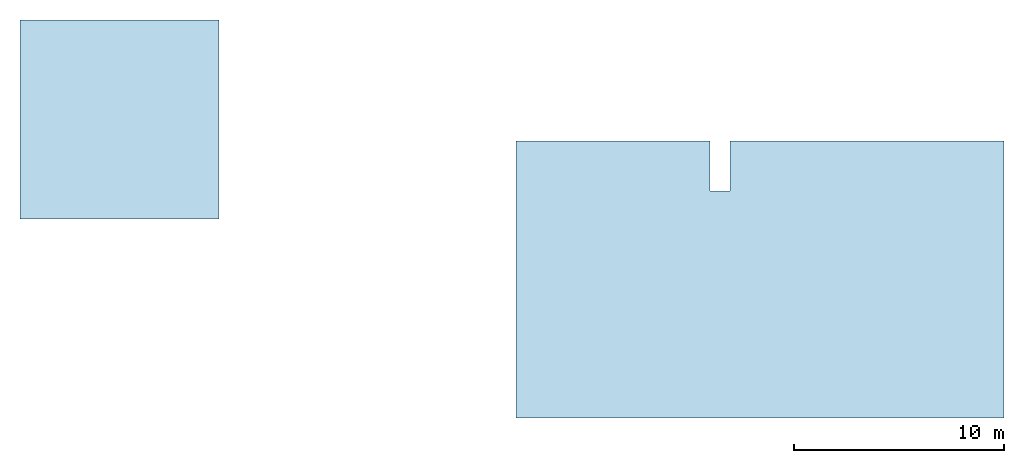
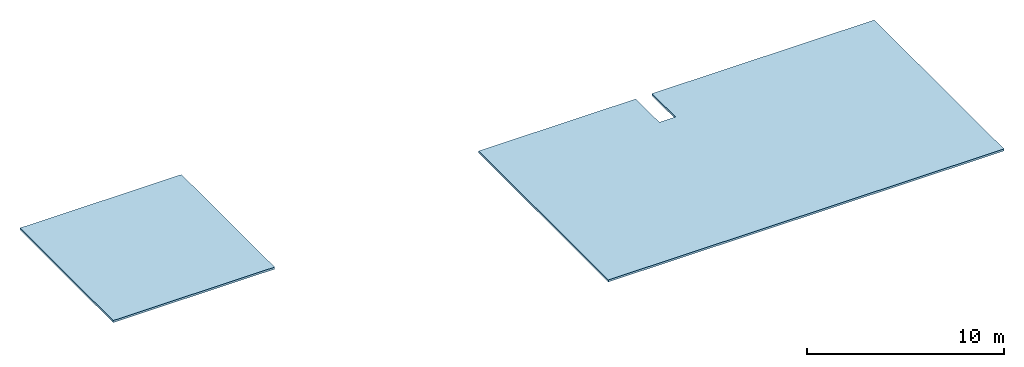
# One storey: 2 slabs, 1 opening, 2 elements without a shape of their own.
"""IFC2X3 building model written with IfcOpenShell, lengths in millimetres."""

from ifc_helpers import new_model, entity, si_unit, converted_unit, direction, frame, frame_2d, origin, origin_2d_with_axis, place, context, subcontext, project, spatial, rectangle, extrude, material, layer, layer_set, element, aggregate, save


model = new_model("IFC2X3")

# Units and contexts
model_context = context("Model", 3, precision=1e-06, world=origin(), true_north=direction((2.0, 6.12303176911189e-17, 1.0)))
context_of_model = context(None, 3, precision=1e-06, world=origin(), true_north=direction((2.0, 6.12303176911189e-17, 1.0)))
body_context = subcontext(model_context, "Body", "Model", "MODEL_VIEW")
ifc_project = project(units=[si_unit("LENGTHUNIT", "METRE", prefix="MILLI"), si_unit("AREAUNIT", "SQUARE_METRE", prefix="MILLI"), si_unit("VOLUMEUNIT", "CUBIC_METRE", prefix="MILLI"), converted_unit("PLANEANGLEUNIT", "DEGREE", entity("IfcRatioMeasure", 0.0174532925199433), si_unit("PLANEANGLEUNIT", "RADIAN"), dimensions=[0, 0, 0, 0, 0, 0, 0]), si_unit("TIMEUNIT", "SECOND")], contexts=[model_context, context_of_model])

# Site, building, storey
site_placement = place(None, origin())
site = spatial("IfcSite", under=ifc_project, at=site_placement, CompositionType="ELEMENT")
building_placement = place(site_placement, origin())
building = spatial("IfcBuilding", under=site, at=building_placement, CompositionType="ELEMENT")
storey_placement = place(building_placement, frame((0.0, 0.0, 4500.0)))
storey = spatial("IfcBuildingStorey", under=building, at=storey_placement, Name="Level 2", CompositionType="ELEMENT", Elevation=4500.0)

# Roof, slab, opening
roof_1_placement = place(storey_placement, origin())
roof_1 = element("IfcRoof", 1, at=roof_1_placement, inside=storey, Name="Basic Roof:Generic - 125mm", ObjectType="Basic Roof:Generic - 125mm", ShapeType="NOTDEFINED")
ifc_material = material(Name="Default Roof")
ifc_layer = layer(ifc_material, 125.0)
ifc_layer_set = layer_set([ifc_layer], Name="Basic Roof:Generic - 125mm")
slab_1_placement = place(roof_1_placement, frame((-2090.0, -7230.0, 0.0)))
slab_1 = element("IfcSlab", 2, at=slab_1_placement, material=ifc_layer_set, Name="Basic Roof:Generic - 125mm", ObjectType="Basic Roof:Generic - 125mm", PredefinedType="ROOF", context=body_context, shape_type="SweptSolid", body=[
    extrude(rectangle(XDim=23228.1610822873, YDim=13200.0, at=frame_2d((0.0, 0.0), x_axis=(-1.0, 0.0))), frame((11614.0805411436, 6600.0, 0.0)), (0.0, 0.0, 1.0), 125.0),
])
opening_placement = place(roof_1_placement, frame((7615.0, 6680.0, 0.0)))
element("IfcOpeningElement", 3, at=opening_placement, cuts=slab_1, Name="Basic Roof:Generic - 125mm:2", ObjectType="Opening", context=body_context, shape_type="SweptSolid", body=[
    extrude(rectangle(XDim=949.999999999997, YDim=6200.0, at=origin_2d_with_axis()), origin(), (0.0, 0.0, 1.0), 125.0),
])
aggregate(roof_1, [slab_1])

# Roof, slab
roof_2_placement = place(storey_placement, origin())
roof_2 = element("IfcRoof", 4, at=roof_2_placement, inside=storey, Name="Basic Roof:Generic - 125mm", ObjectType="Basic Roof:Generic - 125mm", ShapeType="NOTDEFINED")
slab_2_placement = place(roof_2_placement, frame((-25700.0, 2240.0, 0.0)))
slab_2 = element("IfcSlab", 5, at=slab_2_placement, material=ifc_layer_set, Name="Basic Roof:Generic - 125mm", ObjectType="Basic Roof:Generic - 125mm", PredefinedType="ROOF", context=body_context, shape_type="SweptSolid", body=[
    extrude(rectangle(XDim=9480.0, YDim=9480.00000002438, at=origin_2d_with_axis()), frame((4740.0, 4740.0, 0.0)), (0.0, 0.0, 1.0), 125.0),
])
aggregate(roof_2, [slab_2])

save(model, "model.ifc")
